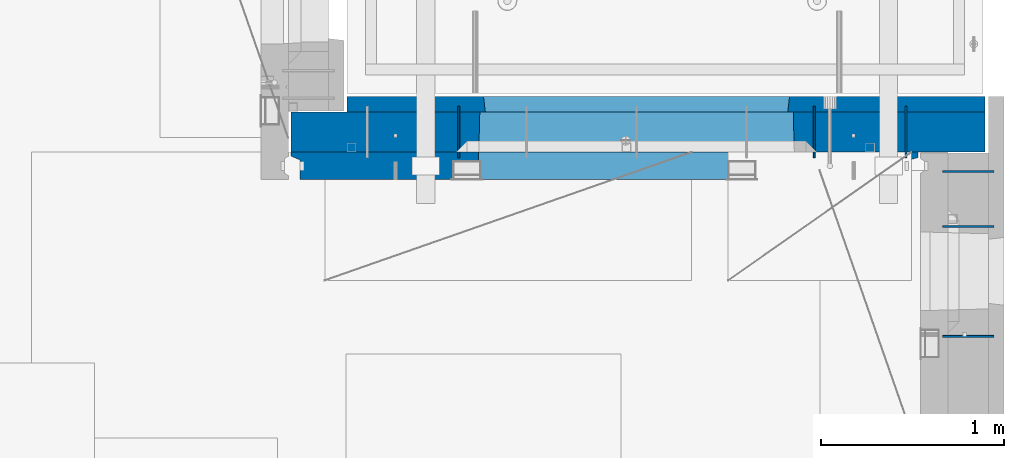
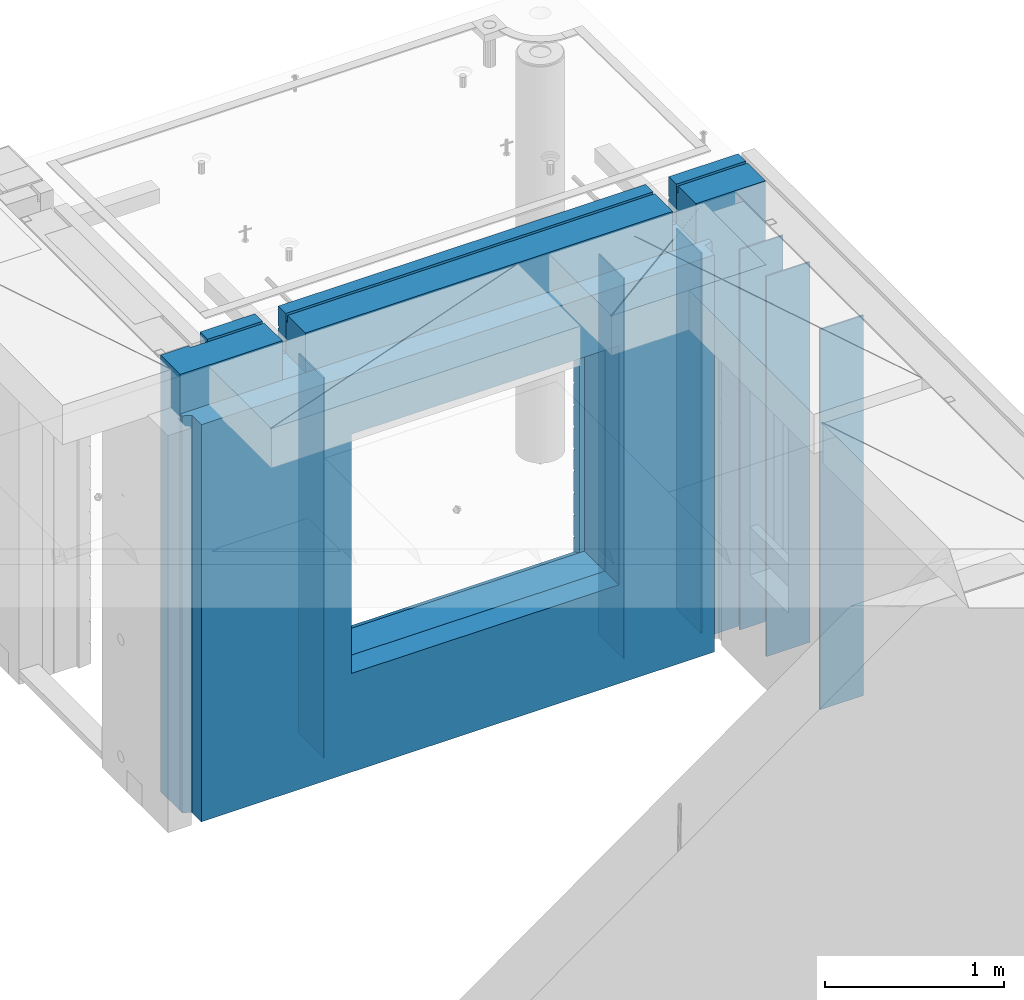
# One storey, part 242 of 349: 9 walls, 2 elements without a shape of their own.
"""IFC2X3 building model written with IfcOpenShell, lengths in millimetres."""

from ifc_helpers import new_model, si_unit, frame, origin_with_axes, place, context, subcontext, project, spatial, faceted_brep, material, type_object, element, aggregate, save


model = new_model("IFC2X3")

# Units and contexts
model_context = context("Model", 3, precision=1e-05, world=origin_with_axes())
body_context = subcontext(model_context, "Body", "Model", "MODEL_VIEW")
ifc_project = project(units=[si_unit("LENGTHUNIT", "METRE", prefix="MILLI"), si_unit("AREAUNIT", "SQUARE_METRE"), si_unit("VOLUMEUNIT", "CUBIC_METRE"), si_unit("MASSUNIT", "GRAM", prefix="KILO"), si_unit("TIMEUNIT", "SECOND"), si_unit("PLANEANGLEUNIT", "RADIAN"), si_unit("SOLIDANGLEUNIT", "STERADIAN"), si_unit("THERMODYNAMICTEMPERATUREUNIT", "DEGREE_CELSIUS"), si_unit("LUMINOUSINTENSITYUNIT", "LUMEN")], contexts=[model_context])

# Site, building, storey
site_placement = place(None, origin_with_axes())
site = spatial("IfcSite", under=ifc_project, at=site_placement, CompositionType="ELEMENT")
building_placement = place(site_placement, origin_with_axes())
building = spatial("IfcBuilding", under=site, at=building_placement, CompositionType="ELEMENT")
storey_placement = place(building_placement, origin_with_axes())
storey = spatial("IfcBuildingStorey", under=building, at=storey_placement, Name="4", CompositionType="ELEMENT", Elevation=0.0)

# Assembly, walls
assembly_1_placement = place(storey_placement, origin_with_axes())
assembly_1 = element("IfcElementAssembly", 1, at=assembly_1_placement, inside=storey, AssemblyPlace="NOTDEFINED", PredefinedType="REINFORCEMENT_UNIT")
ifc_material_1 = material(Name="Undefined")
wall_type_1 = type_object("IfcWallType", PredefinedType="NOTDEFINED")
wall_1_placement = place(assembly_1_placement, frame((34830.0, 20549.9951872276, 92115.0), z_axis=(0.0, 0.0, 1.0), x_axis=(0.0, 1.0, 0.0)))
wall_1 = element("IfcWall", 2, at=wall_1_placement, type_object=wall_type_1, material=ifc_material_1, Name="(PD)", context=body_context, shape_type="Brep", body=[
    faceted_brep([(0.0, 5.0, -1300.0), (0.0, 5.0, 1300.0), (280.0, 5.0, 1300.0), (280.0, 5.0, -1300.0), (0.0, -5.0, 1300.0), (280.0, -5.0, 1300.0), (0.0, -5.0, -1300.0), (280.0, -5.0, -1300.0)], [[[0, 1, 2, 3]], [[1, 4, 5, 2]], [[4, 6, 7, 5]], [[6, 0, 3, 7]], [[5, 7, 3, 2]], [[6, 4, 1, 0]]]),
])
wall_2_placement = place(assembly_1_placement, frame((34330.0, 20549.9951872276, 92115.0), z_axis=(0.0, 0.0, 1.0), x_axis=(0.0, 1.0, 0.0)))
wall_2 = element("IfcWall", 3, at=wall_2_placement, type_object=wall_type_1, material=ifc_material_1, Name="(PD)", context=body_context, shape_type="Brep", body=[
    faceted_brep([(0.0, 5.0, -1300.0), (0.0, 5.0, 1300.0), (280.0, 5.0, 1300.0), (280.0, 5.0, -1300.0), (0.0, -5.0, 1300.0), (280.0, -5.0, 1300.0), (0.0, -5.0, -1300.0), (280.0, -5.0, -1300.0)], [[[0, 1, 2, 3]], [[1, 4, 5, 2]], [[4, 6, 7, 5]], [[6, 0, 3, 7]], [[5, 7, 3, 2]], [[6, 4, 1, 0]]]),
])
wall_3_placement = place(assembly_1_placement, frame((32390.0, 20549.9951872276, 92115.0), z_axis=(0.0, 0.0, 1.0), x_axis=(0.0, 1.0, 0.0)))
wall_3 = element("IfcWall", 4, at=wall_3_placement, type_object=wall_type_1, material=ifc_material_1, Name="(PD)", context=body_context, shape_type="Brep", body=[
    faceted_brep([(0.0, 5.0, -1300.0), (0.0, 5.0, 1300.0), (280.0, 5.0, 1300.0), (280.0, 5.0, -1300.0), (0.0, -5.0, 1300.0), (280.0, -5.0, 1300.0), (0.0, -5.0, -1300.0), (280.0, -5.0, -1300.0)], [[[0, 1, 2, 3]], [[1, 4, 5, 2]], [[4, 6, 7, 5]], [[6, 0, 3, 7]], [[5, 7, 3, 2]], [[6, 4, 1, 0]]]),
])

assembly_2_placement = place(storey_placement, origin_with_axes())
assembly_2 = element("IfcElementAssembly", 5, at=assembly_2_placement, inside=storey, AssemblyPlace="NOTDEFINED", PredefinedType="REINFORCEMENT_UNIT")
wall_4_placement = place(assembly_2_placement, frame((35030.0, 20175.0002441406, 92115.0), z_axis=(0.0, 0.0, 1.0), x_axis=(1.0, 0.0, 0.0)))
wall_4 = element("IfcWall", 6, at=wall_4_placement, type_object=wall_type_1, material=ifc_material_1, Name="(PD)", context=body_context, shape_type="Brep", body=[
    faceted_brep([(0.0, 5.0, -1300.0), (0.0, 5.0, 1300.0), (280.0, 5.0, 1300.0), (280.0, 5.0, -1300.0), (0.0, -5.0, 1300.0), (280.0, -5.0, 1300.0), (0.0, -5.0, -1300.0), (280.0, -5.0, -1300.0)], [[[0, 1, 2, 3]], [[1, 4, 5, 2]], [[4, 6, 7, 5]], [[6, 0, 3, 7]], [[5, 7, 3, 2]], [[6, 4, 1, 0]]]),
])
wall_5_placement = place(assembly_2_placement, frame((35030.0, 20475.0002441406, 92115.0), z_axis=(0.0, 0.0, 1.0), x_axis=(1.0, 0.0, 0.0)))
wall_5 = element("IfcWall", 7, at=wall_5_placement, type_object=wall_type_1, material=ifc_material_1, Name="(PD)", context=body_context, shape_type="Brep", body=[
    faceted_brep([(0.0, 5.0, -1300.0), (0.0, 5.0, 1300.0), (280.0, 5.0, 1300.0), (280.0, 5.0, -1300.0), (0.0, -5.0, 1300.0), (280.0, -5.0, 1300.0), (0.0, -5.0, -1300.0), (280.0, -5.0, -1300.0)], [[[0, 1, 2, 3]], [[1, 4, 5, 2]], [[4, 6, 7, 5]], [[6, 0, 3, 7]], [[5, 7, 3, 2]], [[6, 4, 1, 0]]]),
])
wall_6_placement = place(assembly_2_placement, frame((35030.0, 19575.0002441406, 92115.0), z_axis=(0.0, 0.0, 1.0), x_axis=(1.0, 0.0, 0.0)))
wall_6 = element("IfcWall", 8, at=wall_6_placement, type_object=wall_type_1, material=ifc_material_1, Name="(PD)", context=body_context, shape_type="Brep", body=[
    faceted_brep([(0.0, 5.0, -1300.0), (0.0, 5.0, 1300.0), (280.0, 5.0, 1300.0), (280.0, 5.0, -1300.0), (0.0, -5.0, 1300.0), (280.0, -5.0, 1300.0), (0.0, -5.0, -1300.0), (280.0, -5.0, -1300.0)], [[[0, 1, 2, 3]], [[1, 4, 5, 2]], [[4, 6, 7, 5]], [[6, 0, 3, 7]], [[5, 7, 3, 2]], [[6, 4, 1, 0]]]),
])
aggregate(assembly_2, [wall_4, wall_5, wall_6])

# Wall
ifc_material_2 = material(Name="COS5gt")
wall_type_2 = type_object("IfcWallType", PredefinedType="NOTDEFINED")
wall_7_placement = place(assembly_1_placement, frame((31475.0, 20689.9951872276, 92247.5), z_axis=(0.0, 0.0, 1.0), x_axis=(1.0, 0.0, 0.0)))
wall_7 = element("IfcWall", 9, at=wall_7_placement, type_object=wall_type_2, material=ifc_material_2, context=body_context, shape_type="Brep", body=[
    faceted_brep([(810.0, 110.0, 1442.5), (810.0, 90.0, 1442.5), (3185.0, 90.0, 1442.5), (3185.0, 110.0, 1442.5), (810.0, 90.0, 1492.5), (810.0, -110.0, 1492.5), (3185.0, -110.0, 1492.5), (3185.0, 90.0, 1492.5), (184.0, 90.0, 1442.5), (184.0, 90.0, 1492.5), (660.0, 90.0, 1492.5), (660.0, 90.0, 1442.5), (184.0, 110.0, 1492.5), (184.0, 110.0, 1442.5), (0.0, 110.0, 1492.5), (0.0, -110.0, 1492.5), (660.0, -110.0, 1492.5), (0.0, -110.0, -1492.5), (0.0, 110.0, -1492.5), (3785.0, 90.0, -1492.5), (184.0, 90.0, -1492.5), (184.0, 90.0, -1442.5), (3785.0, 90.0, -1442.5), (3785.0, -110.0, -1492.5), (184.0, 110.0, -1492.5), (184.0, 110.0, -1442.5), (3785.0, 110.0, -1442.5), (3785.0, 110.0, 1442.5), (3785.0, 90.0, 1442.5), (3785.0, 90.0, 1492.5), (3785.0, -110.0, 1492.5), (3335.0, 90.0, 1492.5), (3335.0, -110.0, 1492.5), (3185.0, -110.000000000004, 1222.5), (810.0, -110.0, 1222.5), (660.0, -110.0, 1222.5), (3335.0, -110.000000000004, 1222.5), (1024.05429979644, -110.000000000004, -813.445945945947), (1024.05429979644, -110.000000000004, 813.445945945947), (2745.94619168834, -110.000000000004, 813.445945945947), (2745.94619168834, -110.000000000004, -813.445945945947), (1030.00024574239, 110.0, -802.5), (1030.00024574239, 110.0, 807.5), (1030.00024574239, 110.0, -807.5), (2740.00024574239, 110.0, -807.5), (2710.00024574239, 110.0, -807.5), (1060.00024574239, 110.0, -807.5), (2740.00024574239, 110.0, 807.5), (2740.00024574239, 110.0, -802.5), (660.0, 110.0, 1442.5), (660.0, 109.999999999996, 1222.5), (810.0, 109.999999999996, 1222.5), (3185.0, 109.999999999996, 1222.5), (3335.0, 109.999999999996, 1222.5), (3335.0, 110.0, 1442.5), (3335.0, 90.0, 1442.5)], [[[0, 1, 2, 3]], [[4, 5, 6, 7]], [[8, 9, 10, 11]], [[12, 9, 8, 13]], [[9, 12, 14, 15, 16, 10]], [[17, 15, 14, 18]], [[19, 20, 21, 22]], [[23, 17, 18, 24, 20, 19]], [[25, 21, 20, 24]], [[26, 22, 21, 25]], [[27, 28, 29, 30, 23, 19, 22, 26]], [[30, 29, 31, 32]], [[33, 6, 5, 34, 35, 16, 15, 17, 23, 30, 32, 36], [37, 38, 39, 40]], [[41, 42, 38, 37, 43]], [[40, 44, 45, 46, 43, 37]], [[39, 47, 48, 44, 40]], [[38, 42, 47, 39]], [[27, 26, 25, 24, 18, 14, 12, 13, 49, 50, 51, 0, 3, 52, 53, 54], [41, 43, 46, 45, 44, 48, 47, 42]], [[28, 27, 54, 55]], [[29, 28, 55, 31]], [[54, 53, 36, 32, 31, 55]], [[52, 33, 36, 53]], [[3, 2, 7, 6, 33, 52]], [[1, 4, 7, 2]], [[0, 51, 34, 5, 4, 1]], [[50, 35, 34, 51]], [[49, 11, 10, 16, 35, 50]], [[13, 8, 11, 49]]]),
])

ifc_material_3 = material(Name="CONCRETE/C30/37")
wall_type_3 = type_object("IfcWallType", PredefinedType="NOTDEFINED")
wall_8_placement = place(assembly_1_placement, frame((31780.0, 20842.4951872276, 92247.5), z_axis=(0.0, 0.0, 1.0), x_axis=(1.0, 0.0, 0.0)))
wall_8 = element("IfcWall", 10, at=wall_8_placement, type_object=wall_type_3, material=ifc_material_3, context=body_context, shape_type="Brep", body=[
    faceted_brep([(3480.0, -42.5, 1492.5), (3480.0, 42.5, 1492.5), (3030.0, 42.5, 1492.5), (3030.0, -42.5, 1492.5), (3480.0, 42.4999992431694, 1356.99999988925), (3030.0, 42.4999993410347, 1356.99999988925), (3480.0, 32.4999991127006, 1355.00000040044), (3480.0, 32.4999992507037, 1344.99999999926), (3030.0, 32.4999992507037, 1344.99999999926), (3030.0, 32.4999991127006, 1355.00000040044), (3480.0, 42.4999996036895, 1342.99999994476), (3030.0, 42.4999996549377, 1342.99999994476), (3480.0, 42.4999993831152, 892.999999944761), (0.0, 42.5, 892.999999944761), (0.0, 32.4999992507037, 894.999999999258), (3480.0, 32.4999992507037, 894.999999999258), (0.0, 32.4999991127006, 905.00000040044), (3480.0, 32.4999991127006, 905.00000040044), (3480.0, 42.4999992431694, 906.999999889245), (0.0, 42.5, 906.999999889245), (0.0, 42.5, 1042.99999994476), (3480.0, 42.4999994189675, 1042.99999994476), (0.0, 32.4999992507037, 1044.99999999926), (3480.0, 32.4999992507037, 1044.99999999926), (0.0, 32.4999991127006, 1055.00000040044), (3480.0, 32.4999991127006, 1055.00000040044), (3480.0, 42.4999992431694, 1056.99999988925), (0.0, 42.5, 1056.99999988925), (0.0, 42.5, 1192.99999994476), (3480.0, 42.4999994795144, 1192.99999994476), (0.0, 32.4999992507037, 1194.99999999926), (3480.0, 32.4999992507037, 1194.99999999926), (0.0, 32.4999991127006, 1205.00000040044), (3480.0, 32.4999991127006, 1205.00000040044), (3480.0, 42.4999992431694, 1206.99999988925), (0.0, 42.5, 1206.99999988925), (-3.63797880709171e-12, 32.4999992507037, 1344.99999999926), (-3.63797880709171e-12, 32.4999991127006, 1355.00000040044), (355.0, 32.4999991127006, 1355.00000040044), (355.0, 32.4999992507037, 1344.99999999926), (0.0, 42.5, 1342.99999994476), (355.0, 42.4999999595711, 1342.99999994476), (505.0, 32.4999992507037, 1344.99999999926), (505.0, 32.4999991127006, 1355.00000040044), (2880.0, 32.4999991127006, 1355.00000040044), (2880.0, 32.4999992507037, 1344.99999999926), (505.0, 42.4999999424908, 1342.99999994476), (2880.0, 42.4999996720217, 1342.99999994476), (355.0, 42.4999998715975, 1222.5), (505.0, 42.4999998467429, 1222.5), (2880.0, 42.4999994331811, 1222.5), (3030.0, 42.4999994081736, 1222.5), (355.0, -42.5, 1222.5), (505.0, -42.5, 1222.5), (505.0, 42.5, 1492.5), (505.0, 42.4999998901731, 1356.99999988925), (505.0, -42.5, 1492.5), (2880.0, -42.5, 1492.5), (2880.0, 42.5, 1492.5), (2880.0, 42.4999993736565, 1356.99999988925), (2880.0, -42.5000000000036, 1222.5), (3030.0, -42.5000000000036, 1222.5), (3480.0, -42.5, -1492.5), (3480.0, 42.5, -1492.5), (3480.0, 42.5, -1357.00000005524), (3480.0, 32.4999992507037, -1355.00000000074), (3480.0, 32.4999991127006, -1344.99999959956), (3480.0, 42.4999992431694, -1343.00000011075), (3480.0, 42.4999992794692, -1207.00000005524), (3480.0, 32.4999992507037, -1205.00000000074), (3480.0, 32.4999991127006, -1194.99999959956), (3480.0, 42.4999992431694, -1193.00000011075), (3480.0, 42.4999992814955, -1057.00000005524), (3480.0, 32.4999992507037, -1055.00000000074), (3480.0, 32.4999991127006, -1044.99999959956), (3480.0, 42.4999992431694, -1043.00000011075), (3480.0, 42.4999992837656, -907.000000055239), (3480.0, 32.4999992507037, -905.000000000742), (3480.0, 32.4999991127006, -894.99999959956), (3480.0, 42.4999992431694, -893.000000110755), (3480.0, 42.4999992863159, -757.000000055239), (3480.0, 32.4999992507037, -755.000000000742), (3480.0, 32.4999991127006, -744.99999959956), (3480.0, 42.4999992431694, -743.000000110755), (3480.0, 42.4999992892117, -607.000000055239), (3480.0, 32.4999992507037, -605.000000000742), (3480.0, 32.4999991127006, -594.99999959956), (3480.0, 42.4999992431694, -593.000000110755), (3480.0, 42.4999992925223, -457.000000055239), (3480.0, 32.4999992507037, -455.000000000742), (3480.0, 32.4999991127006, -444.99999959956), (3480.0, 42.4999992431694, -443.000000110755), (3480.0, 42.4999992963494, -307.000000055239), (3480.0, 32.4999992507037, -305.000000000742), (3480.0, 32.4999991127006, -294.99999959956), (3480.0, 42.4999992431694, -293.000000110755), (3480.0, 42.4999993008169, -157.000000055239), (3480.0, 32.4999992507037, -155.000000000742), (3480.0, 32.4999991127006, -144.99999959956), (3480.0, 42.4999992431694, -143.000000110755), (3480.0, 42.4999993061028, -7.00000005523907), (3480.0, 32.4999992507037, -5.00000000074215), (3480.0, 32.4999991127006, 5.0000004004396), (3480.0, 42.4999992431694, 6.99999988924537), (3480.0, 42.4999993124584, 142.999999944761), (3480.0, 32.4999992507037, 144.999999999258), (3480.0, 32.4999991127006, 155.00000040044), (3480.0, 42.4999992431694, 156.999999889245), (3480.0, 42.49999932024, 292.999999944761), (3480.0, 32.4999992507037, 294.999999999258), (3480.0, 32.4999991127006, 305.00000040044), (3480.0, 42.4999992431694, 306.999999889245), (3480.0, 42.4999993299934, 442.999999944761), (3480.0, 32.4999992507037, 444.999999999258), (3480.0, 32.4999991127006, 455.00000040044), (3480.0, 42.4999992431694, 456.999999889245), (3480.0, 42.4999993425699, 592.999999944761), (3480.0, 32.4999992507037, 594.999999999258), (3480.0, 32.4999991127006, 605.00000040044), (3480.0, 42.4999992431694, 606.999999889245), (3480.0, 42.4999993594065, 742.999999944761), (3480.0, 32.4999992507037, 744.999999999258), (3480.0, 32.4999991127006, 755.00000040044), (3480.0, 42.4999992431694, 756.999999889245), (0.0, -42.5, -1492.5), (0.0, 42.5, -1492.5), (0.0, 42.5, -1357.00000005524), (0.0, 32.4999992507037, -1355.00000000074), (0.0, 32.4999991127006, -1344.99999959956), (0.0, 42.5, -1343.00000011075), (0.0, 42.5, -1207.00000005524), (0.0, 32.4999992507037, -1205.00000000074), (0.0, 32.4999991127006, -1194.99999959956), (0.0, 42.5, -1193.00000011075), (0.0, 42.5, -1057.00000005524), (0.0, 32.4999992507037, -1055.00000000074), (0.0, 32.4999991127006, -1044.99999959956), (0.0, 42.5, -1043.00000011075), (0.0, 42.5, -907.000000055239), (0.0, 32.4999992507037, -905.000000000742), (0.0, 32.4999991127006, -894.99999959956), (0.0, 42.5, -893.000000110755), (0.0, 32.4999991127006, 755.00000040044), (0.0, 42.5, 756.999999889245), (745.000245742391, 42.4999998379753, 756.999999889245), (746.176716435013, 32.4999991127006, 755.00000040044), (0.0, 32.4999992507037, 744.999999999258), (746.17671641878, 32.4999992507037, 744.999999999258), (0.0, 42.5, 742.999999944761), (745.000245742391, 42.4999998628628, 742.999999944761), (0.0, 42.5, 606.999999889245), (745.000245742391, 42.4999998379753, 606.999999889245), (3.63797880709171e-12, 32.4999991127006, 605.00000040044), (746.176716435013, 32.4999991127006, 605.00000040044), (3.63797880709171e-12, 32.4999992507037, 594.999999999258), (746.176716418777, 32.4999992507037, 594.999999999258), (0.0, 42.5, 592.999999944761), (745.000245742391, 42.4999998592575, 592.999999944761), (0.0, 42.5, 456.999999889245), (745.000245742391, 42.4999998379753, 456.999999889245), (0.0, 32.4999991127006, 455.00000040044), (746.176716435013, 32.4999991127006, 455.00000040044), (0.0, 32.4999992507037, 444.999999999258), (746.17671641878, 32.4999992507037, 444.999999999258), (0.0, 42.5, 442.999999944761), (745.000245742391, 42.4999998565654, 442.999999944761), (0.0, 42.5, 306.999999889245), (745.000245742391, 42.4999998379753, 306.999999889245), (-3.63797880709171e-12, 32.4999991127006, 305.00000040044), (746.176716435013, 32.4999991127006, 305.00000040044), (-3.63797880709171e-12, 32.4999992507037, 294.999999999258), (746.176716418777, 32.4999992507037, 294.999999999258), (0.0, 42.5, 292.999999944761), (745.000245742391, 42.4999998544772, 292.999999944761), (0.0, 42.5, 156.999999889245), (745.000245742391, 42.4999998379753, 156.999999889245), (-3.63797880709171e-12, 32.4999991127006, 155.00000040044), (746.176716435013, 32.4999991127006, 155.00000040044), (-3.63797880709171e-12, 32.4999992507037, 144.999999999258), (746.176716418777, 32.4999992507037, 144.999999999258), (0.0, 42.5, 142.999999944761), (745.000245742391, 42.499999852811, 142.999999944761), (0.0, 42.5, 6.99999988924537), (745.000245742391, 42.4999998379753, 6.99999988924537), (0.0, 32.4999991127006, 5.0000004004396), (746.176716435013, 32.4999991127006, 5.0000004004396), (0.0, 32.4999992507037, -5.00000000074215), (746.17671641878, 32.4999992507037, -5.00000000074215), (0.0, 42.5, -7.00000005523907), (745.000245742391, 42.4999998514504, -7.00000005523907), (0.0, 42.5, -143.000000110755), (745.000245742391, 42.4999998379753, -143.000000110755), (3.63797880709171e-12, 32.4999991127006, -144.99999959956), (746.176716435013, 32.4999991127006, -144.99999959956), (3.63797880709171e-12, 32.4999992507037, -155.000000000742), (746.176716418777, 32.4999992507037, -155.000000000742), (0.0, 42.5, -157.000000055239), (745.000245742391, 42.499999850319, -157.000000055239), (0.0, 42.5, -293.000000110755), (745.000245742391, 42.4999998379753, -293.000000110755), (0.0, 32.4999991127006, -294.99999959956), (746.176716435013, 32.4999991127006, -294.99999959956), (0.0, 32.4999992507037, -305.000000000742), (746.17671641878, 32.4999992507037, -305.000000000742), (0.0, 42.5, -307.000000055239), (745.000245742391, 42.4999998493622, -307.000000055239), (0.0, 42.5, -443.000000110755), (745.000245742391, 42.4999998379753, -443.000000110755), (0.0, 32.4999991127006, -444.99999959956), (746.176716435013, 32.4999991127006, -444.99999959956), (0.0, 32.4999992507037, -455.000000000742), (746.17671641878, 32.4999992507037, -455.000000000742), (0.0, 42.5, -457.000000055239), (745.000245742391, 42.4999998485437, -457.000000055239), (0.0, 42.5, -593.000000110755), (745.000245742391, 42.4999998379753, -593.000000110755), (3.63797880709171e-12, 32.4999991127006, -594.99999959956), (746.176716435013, 32.4999991127006, -594.99999959956), (3.63797880709171e-12, 32.4999992507037, -605.000000000742), (746.176716418777, 32.4999992507037, -605.000000000742), (0.0, 42.5, -607.000000055239), (745.000245742391, 42.4999998478343, -607.000000055239), (0.0, 42.5, -743.000000110755), (745.000245742391, 42.4999998379753, -743.000000110755), (0.0, 32.4999991127006, -744.99999959956), (746.176716435013, 32.4999991127006, -744.99999959956), (0.0, 32.4999992507037, -755.000000000742), (746.17671641878, 32.4999992507037, -755.000000000742), (0.0, 42.5, -757.000000055239), (745.000245742391, 42.4999998472158, -757.000000055239), (745.000245742391, 42.5, -857.5), (755.000245742391, -42.5, -807.5), (2405.00024574239, -42.5, -807.5), (2415.00024574239, 42.5, -857.5), (2415.00024574239, 42.4999995047292, -757.000000055239), (2413.823775066, 32.4999992507037, -755.000000000742), (2413.82377504977, 32.4999991127006, -744.99999959956), (2415.00024574239, 42.499999474785, -743.000000110755), (2415.00024574239, 42.4999995067374, -607.000000055239), (2413.823775066, 32.4999992507037, -605.000000000742), (2413.82377504977, 32.4999991127006, -594.99999959956), (2415.00024574239, 42.499999474785, -593.000000110755), (2415.00024574239, 42.4999995090366, -457.000000055239), (2413.823775066, 32.4999992507037, -455.000000000742), (2413.82377504977, 32.4999991127006, -444.99999959956), (2415.00024574239, 42.499999474785, -443.000000110755), (2415.00024574239, 42.4999995116923, -307.000000055239), (2413.823775066, 32.4999992507037, -305.000000000742), (2413.82377504977, 32.4999991127006, -294.99999959956), (2415.00024574239, 42.499999474785, -293.000000110755), (2415.00024574239, 42.4999995147919, -157.000000055239), (2413.823775066, 32.4999992507037, -155.000000000742), (2413.82377504977, 32.4999991127006, -144.99999959956), (2415.00024574239, 42.499999474785, -143.000000110755), (2415.00024574239, 42.4999995184589, -7.00000005523907), (2413.823775066, 32.4999992507037, -5.00000000074215), (2413.82377504977, 32.4999991127006, 5.0000004004396), (2415.00024574239, 42.499999474785, 6.99999988924537), (2415.00024574239, 42.4999995228682, 142.999999944761), (2413.823775066, 32.4999992507037, 144.999999999258), (2413.82377504977, 32.4999991127006, 155.00000040044), (2415.00024574239, 42.499999474785, 156.999999889245), (2415.00024574239, 42.4999995282706, 292.999999944761), (2413.823775066, 32.4999992507037, 294.999999999258), (2413.82377504977, 32.4999991127006, 305.00000040044), (2415.00024574239, 42.499999474785, 306.999999889245), (2415.00024574239, 42.4999995350372, 442.999999944761), (2413.823775066, 32.4999992507037, 444.999999999258), (2413.82377504977, 32.4999991127006, 455.00000040044), (2415.00024574239, 42.499999474785, 456.999999889245), (2415.00024574239, 42.4999995437647, 592.999999944761), (2413.823775066, 32.4999992507037, 594.999999999258), (2413.82377504977, 32.4999991127006, 605.00000040044), (2415.00024574239, 42.499999474785, 606.999999889245), (2415.00024574239, 42.4999995554499, 742.999999944761), (2413.823775066, 32.4999992507037, 744.999999999258), (2413.82377504977, 32.4999991127006, 755.00000040044), (2415.00024574239, 42.499999474785, 756.999999889245), (755.000245742391, 42.5, 782.5), (745.000245742391, 42.5, 782.5), (2415.00024574239, 42.5, 782.5), (2405.00024574239, 42.5, 782.5), (755.000245742391, -42.5, 782.5), (755.000245742391, -42.5, 787.5), (2405.00024574239, -42.5, 787.5), (2405.00024574239, -42.5, 782.5), (355.0, -42.5, 1492.5), (0.0, -42.5, 1492.5), (0.0, 42.5, 1492.5), (355.0, 42.5, 1492.5), (0.0, 42.5, 1356.99999988925), (355.0, 42.4999999227948, 1356.99999988925)], [[[0, 1, 2, 3]], [[1, 4, 5, 2]], [[6, 7, 8, 9]], [[7, 10, 11, 8]], [[12, 13, 14, 15]], [[15, 14, 16, 17]], [[18, 17, 16, 19]], [[18, 19, 20, 21]], [[21, 20, 22, 23]], [[23, 22, 24, 25]], [[26, 25, 24, 27]], [[26, 27, 28, 29]], [[29, 28, 30, 31]], [[31, 30, 32, 33]], [[34, 33, 32, 35]], [[36, 37, 38, 39]], [[40, 36, 39, 41]], [[42, 43, 44, 45]], [[46, 42, 45, 47]], [[10, 34, 35, 40, 41, 48, 49, 46, 47, 50, 51, 11]], [[48, 52, 53, 49]], [[54, 55, 43, 42, 46, 49, 53, 56]], [[54, 56, 57, 58]], [[55, 54, 58, 59]], [[43, 55, 59, 44]], [[58, 57, 60, 50, 47, 45, 44, 59]], [[50, 60, 61, 51]], [[2, 5, 9, 8, 11, 51, 61, 3]], [[4, 6, 9, 5]], [[1, 0, 62, 63, 64, 65, 66, 67, 68, 69, 70, 71, 72, 73, 74, 75, 76, 77, 78, 79, 80, 81, 82, 83, 84, 85, 86, 87, 88, 89, 90, 91, 92, 93, 94, 95, 96, 97, 98, 99, 100, 101, 102, 103, 104, 105, 106, 107, 108, 109, 110, 111, 112, 113, 114, 115, 116, 117, 118, 119, 120, 121, 122, 123, 12, 15, 17, 18, 21, 23, 25, 26, 29, 31, 33, 34, 10, 7, 6, 4]], [[124, 125, 63, 62]], [[63, 125, 126, 64]], [[64, 126, 127, 65]], [[65, 127, 128, 66]], [[67, 66, 128, 129]], [[67, 129, 130, 68]], [[68, 130, 131, 69]], [[69, 131, 132, 70]], [[71, 70, 132, 133]], [[71, 133, 134, 72]], [[72, 134, 135, 73]], [[73, 135, 136, 74]], [[75, 74, 136, 137]], [[75, 137, 138, 76]], [[76, 138, 139, 77]], [[77, 139, 140, 78]], [[79, 78, 140, 141]], [[142, 143, 144, 145]], [[146, 142, 145, 147]], [[148, 146, 147, 149]], [[150, 148, 149, 151]], [[152, 150, 151, 153]], [[154, 152, 153, 155]], [[156, 154, 155, 157]], [[158, 156, 157, 159]], [[160, 158, 159, 161]], [[162, 160, 161, 163]], [[164, 162, 163, 165]], [[166, 164, 165, 167]], [[168, 166, 167, 169]], [[170, 168, 169, 171]], [[172, 170, 171, 173]], [[174, 172, 173, 175]], [[176, 174, 175, 177]], [[178, 176, 177, 179]], [[180, 178, 179, 181]], [[182, 180, 181, 183]], [[184, 182, 183, 185]], [[186, 184, 185, 187]], [[188, 186, 187, 189]], [[190, 188, 189, 191]], [[192, 190, 191, 193]], [[194, 192, 193, 195]], [[196, 194, 195, 197]], [[198, 196, 197, 199]], [[200, 198, 199, 201]], [[202, 200, 201, 203]], [[204, 202, 203, 205]], [[206, 204, 205, 207]], [[208, 206, 207, 209]], [[210, 208, 209, 211]], [[212, 210, 211, 213]], [[214, 212, 213, 215]], [[216, 214, 215, 217]], [[218, 216, 217, 219]], [[220, 218, 219, 221]], [[222, 220, 221, 223]], [[224, 222, 223, 225]], [[226, 224, 225, 227]], [[228, 226, 227, 229]], [[230, 231, 232, 233]], [[80, 79, 141, 228, 229, 230, 233, 234]], [[81, 80, 234, 235]], [[82, 81, 235, 236]], [[83, 82, 236, 237]], [[84, 83, 237, 238]], [[85, 84, 238, 239]], [[86, 85, 239, 240]], [[87, 86, 240, 241]], [[88, 87, 241, 242]], [[89, 88, 242, 243]], [[90, 89, 243, 244]], [[91, 90, 244, 245]], [[92, 91, 245, 246]], [[93, 92, 246, 247]], [[94, 93, 247, 248]], [[95, 94, 248, 249]], [[96, 95, 249, 250]], [[97, 96, 250, 251]], [[98, 97, 251, 252]], [[99, 98, 252, 253]], [[100, 99, 253, 254]], [[101, 100, 254, 255]], [[102, 101, 255, 256]], [[103, 102, 256, 257]], [[104, 103, 257, 258]], [[105, 104, 258, 259]], [[106, 105, 259, 260]], [[107, 106, 260, 261]], [[108, 107, 261, 262]], [[109, 108, 262, 263]], [[110, 109, 263, 264]], [[111, 110, 264, 265]], [[112, 111, 265, 266]], [[113, 112, 266, 267]], [[114, 113, 267, 268]], [[115, 114, 268, 269]], [[116, 115, 269, 270]], [[117, 116, 270, 271]], [[118, 117, 271, 272]], [[119, 118, 272, 273]], [[120, 119, 273, 274]], [[121, 120, 274, 275]], [[122, 121, 275, 276]], [[123, 122, 276, 277]], [[278, 279, 144, 143, 13, 12, 123, 277, 280, 281]], [[282, 231, 230, 229, 227, 225, 223, 221, 219, 217, 215, 213, 211, 209, 207, 205, 203, 201, 199, 197, 195, 193, 191, 189, 187, 185, 183, 181, 179, 177, 175, 173, 171, 169, 167, 165, 163, 161, 159, 157, 155, 153, 151, 149, 147, 145, 144, 279, 283]], [[278, 281, 280, 284, 283, 279]], [[277, 276, 275, 274, 273, 272, 271, 270, 269, 268, 267, 266, 265, 264, 263, 262, 261, 260, 259, 258, 257, 256, 255, 254, 253, 252, 251, 250, 249, 248, 247, 246, 245, 244, 243, 242, 241, 240, 239, 238, 237, 236, 235, 234, 233, 232, 285, 284, 280]], [[60, 57, 56, 53, 52, 286, 287, 124, 62, 0, 3, 61], [232, 231, 282, 283, 284, 285]], [[288, 287, 286, 289]], [[36, 40, 35, 32, 30, 28, 27, 24, 22, 20, 19, 16, 14, 13, 143, 142, 146, 148, 150, 152, 154, 156, 158, 160, 162, 164, 166, 168, 170, 172, 174, 176, 178, 180, 182, 184, 186, 188, 190, 192, 194, 196, 198, 200, 202, 204, 206, 208, 210, 212, 214, 216, 218, 220, 222, 224, 226, 228, 141, 140, 139, 138, 137, 136, 135, 134, 133, 132, 131, 130, 129, 128, 127, 126, 125, 124, 287, 288, 290, 37]], [[37, 290, 291, 38]], [[289, 286, 52, 48, 41, 39, 38, 291]], [[290, 288, 289, 291]]]),
])

ifc_material_4 = material(Name="CONCRETE/C25/30")
wall_type_4 = type_object("IfcWallType", PredefinedType="NOTDEFINED")
wall_9_placement = place(assembly_1_placement, frame((31475.0, 20504.9951872276, 92112.5), z_axis=(0.0, 0.0, 1.0), x_axis=(1.0, 0.0, 0.0)))
wall_9 = element("IfcWall", 11, at=wall_9_placement, type_object=wall_type_4, material=ifc_material_4, context=body_context, shape_type="Brep", body=[
    faceted_brep([(3370.0, -75.0, 1357.5), (3370.0, -75.0, -1357.5), (3370.0, 32.0, -1357.5), (3370.0, 32.0, 1357.5), (3420.0, 75.0, 1357.5), (0.0, 75.0, 1357.5), (0.0, 53.6645811319431, 1357.5), (49.9951872275633, 32.0, 1357.5), (49.9951872275633, -75.0, 1357.5), (3420.0, 45.0, 1357.5), (49.9951872275633, 32.0, -1357.5), (49.9951872275633, -75.0, -1357.5), (0.0, 53.6645811319431, -1357.5), (0.0, 75.0, -1357.5), (3420.0, 75.0, -1357.5), (3420.0, 45.0, -1357.5), (1020.00024574239, -75.0, 952.5), (1024.05429979644, 75.0, 948.445945945947), (2745.94619168834, 75.0, 948.445945945947), (2750.00024574239, -75.0, 952.5), (1024.05429979644, 75.0, -678.445945945947), (2745.94619168834, 75.0, -678.445945945947), (2750.00024574239, -75.0, -682.5), (1020.00024574239, -75.0, -682.5)], [[[0, 1, 2, 3]], [[4, 5, 6, 7, 8, 0, 3, 9]], [[7, 10, 11, 8]], [[6, 12, 10, 7]], [[5, 13, 12, 6]], [[1, 11, 10, 12, 13, 14, 15, 2]], [[9, 3, 2, 15]], [[14, 4, 9, 15]], [[16, 17, 18, 19]], [[13, 5, 4, 14], [20, 21, 18, 17]], [[19, 18, 21, 22]], [[8, 11, 1, 0], [23, 16, 19, 22]], [[17, 16, 23, 20]], [[22, 21, 20, 23]]]),
])

aggregate(assembly_1, [wall_1, wall_2, wall_3, wall_8, wall_7, wall_9])

save(model, "model.ifc")
